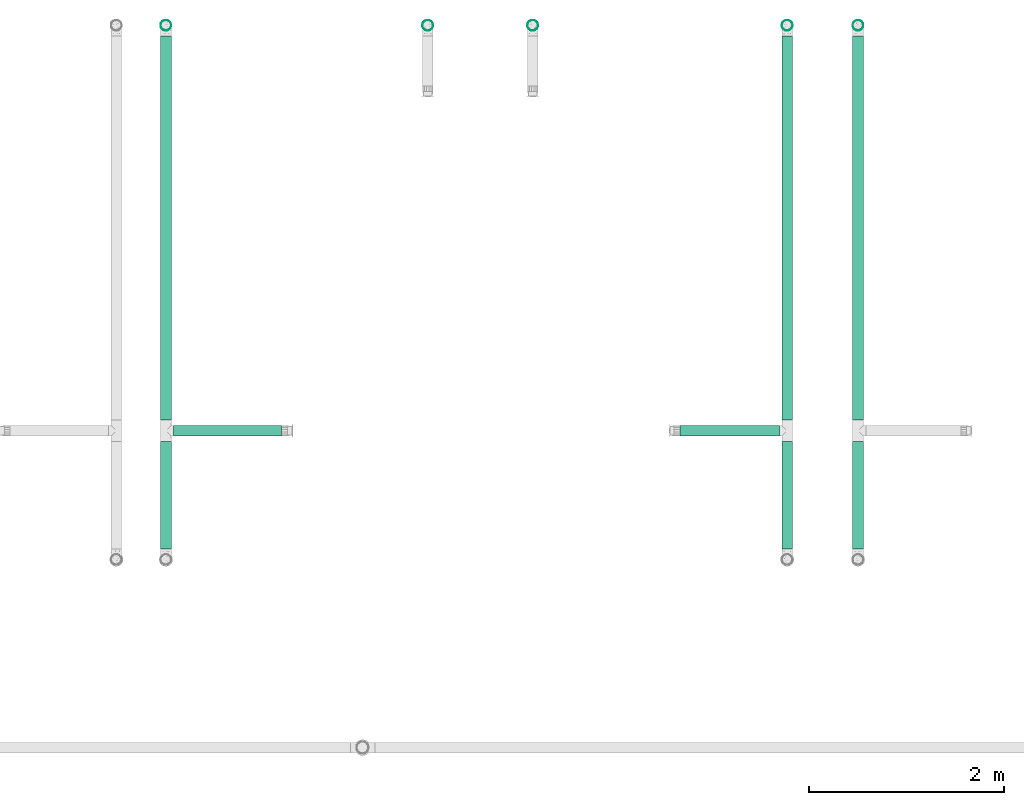
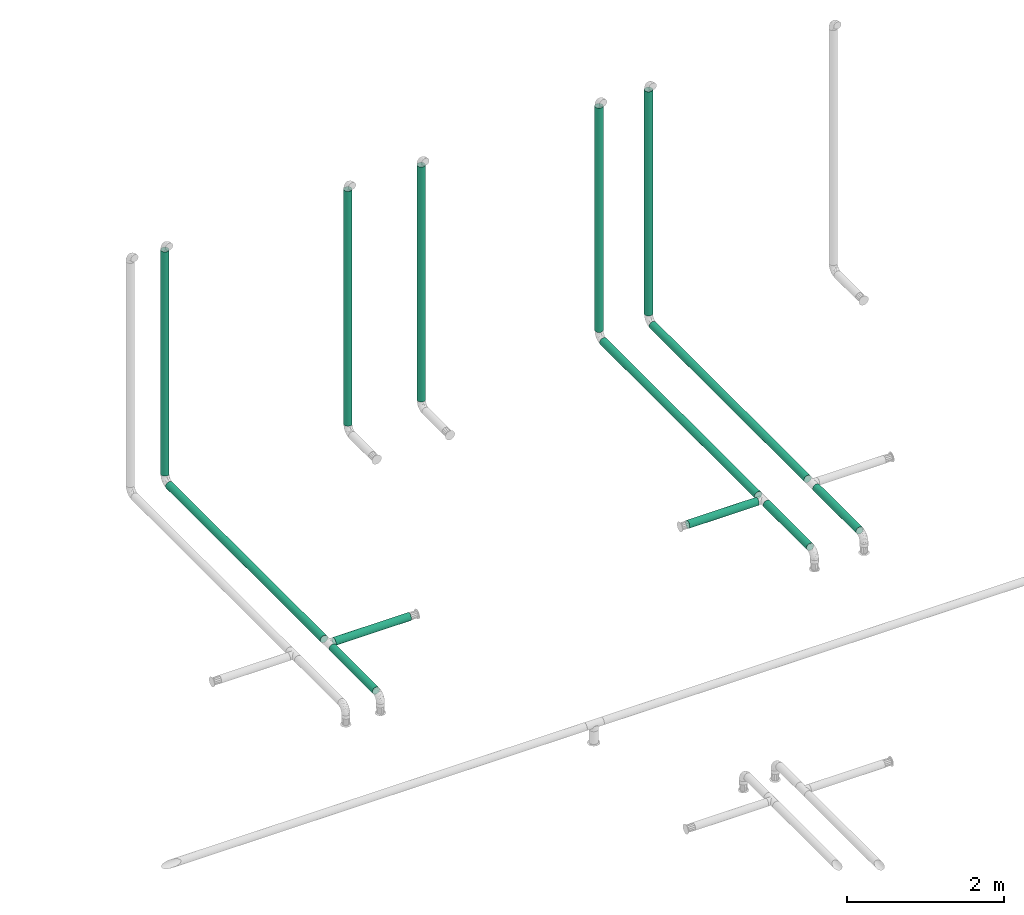
# One storey, part 10 of 115: 13 flow segments.
"""IFC2X3 building model written with IfcOpenShell, lengths in millimetres."""

from ifc_helpers import new_model, entity, si_unit, converted_unit, derived_unit, direction, frame, origin_with_axes, origin_2d_with_axis, place, context, subcontext, project, spatial, hollow_circle, extrude, source, transform, mapped, material, layer, layer_set, layer_usage, type_object, element, save


model = new_model("IFC2X3")

# Units and contexts
model_context = context("Model", 3, precision=1e-05, world=origin_with_axes(), true_north=direction((0.0, 1.0)))
body_context = subcontext(model_context, "Body", "Model", "MODEL_VIEW")
ifc_project = project(units=[si_unit("AREAUNIT", "SQUARE_METRE"), si_unit("VOLUMEUNIT", "CUBIC_METRE", prefix="DECI"), si_unit("TIMEUNIT", "SECOND"), si_unit("THERMODYNAMICTEMPERATUREUNIT", "DEGREE_CELSIUS"), si_unit("PRESSUREUNIT", "PASCAL"), si_unit("MASSUNIT", "GRAM", prefix="KILO"), si_unit("LENGTHUNIT", "METRE", prefix="MILLI"), si_unit("POWERUNIT", "WATT"), si_unit("ELECTRICCURRENTUNIT", "AMPERE"), si_unit("ELECTRICVOLTAGEUNIT", "VOLT"), derived_unit("VOLUMETRICFLOWRATEUNIT", [(si_unit("VOLUMEUNIT", "CUBIC_METRE", prefix="DECI"), 1), (si_unit("TIMEUNIT", "SECOND"), -1)]), derived_unit("LINEARVELOCITYUNIT", [(si_unit("LENGTHUNIT", "METRE"), 1), (si_unit("TIMEUNIT", "SECOND"), -1)]), derived_unit("MASSDENSITYUNIT", [(si_unit("MASSUNIT", "GRAM", prefix="KILO"), 1), (si_unit("VOLUMEUNIT", "CUBIC_METRE"), -1)]), converted_unit("PLANEANGLEUNIT", "DEGREE", entity("IfcRatioMeasure", 0.01745), si_unit("PLANEANGLEUNIT", "RADIAN"), dimensions=[0, 0, 0, 0, 0, 0, 0])], contexts=[model_context])

# Site, building, storey
site_placement = place(None, origin_with_axes())
site = spatial("IfcSite", under=ifc_project, at=site_placement, CompositionType="ELEMENT")
building_placement = place(site_placement, origin_with_axes())
building = spatial("IfcBuilding", under=site, at=building_placement, Name="mc-building", CompositionType="ELEMENT")
storey_placement = place(building_placement, frame((0.0, 0.0, 2950.0), z_axis=(0.0, 0.0, 1.0), x_axis=(1.0, 0.0, 0.0)))
storey = spatial("IfcBuildingStorey", under=building, at=storey_placement, Name="2. Korrus", CompositionType="ELEMENT", Elevation=2950.0)

# Flow segments
ifc_material = material(Name="FZ1")
ifc_layer = layer(ifc_material, 0.0)
ifc_layer_set = layer_set([ifc_layer], Name="FZ1")
ifc_layer_usage = layer_usage(ifc_layer_set, "AXIS1", "POSITIVE", 0.0)
duct_segment_type = type_object("IfcDuctSegmentType", PredefinedType="RIGIDSEGMENT")
shared_shape_1 = source(origin_with_axes(), body_context, "Body", "SweptSolid", [
    extrude(hollow_circle(Radius=55.0, WallThickness=2.0, at=origin_2d_with_axis()), frame((0.0, 0.0, 0.0), z_axis=(1.0, 0.0, 0.0), x_axis=(0.0, 1.0, 0.0)), (0.0, 0.0, 1.0), 3480.0),
])
for number, where, z_axis, x_axis in (
    (1, (33284.80157, 13663.57591, 2575.0), (1.0, 0.0, 0.0), (0.0, 0.0, 1.0)),
    (2, (34011.69824, 13663.57591, 2575.0), (1.0, 0.0, 0.0), (0.0, 0.0, 1.0)),
    (3, (26911.82755, 13663.57591, 2575.0), (1.0, 0.0, 0.0), (0.0, 0.0, 1.0)),
):
    element("IfcFlowSegment", number, at=place(storey_placement, frame(where, z_axis=z_axis, x_axis=x_axis)), inside=storey, type_object=duct_segment_type, material=ifc_layer_usage, context=body_context, shape_type="MappedRepresentation", body=[
        mapped(shared_shape_1, transform((0.0, 0.0, 0.0), scale=1.0)),
    ])
shared_shape_2 = source(origin_with_axes(), body_context, "Body", "SweptSolid", [
    extrude(hollow_circle(Radius=55.0, WallThickness=2.0, at=origin_2d_with_axis()), frame((0.0, 0.0, 0.0), z_axis=(1.0, 0.0, 0.0), x_axis=(0.0, 1.0, 0.0)), (0.0, 0.0, 1.0), 3645.0),
])
for number, where, z_axis, x_axis in (
    (4, (30674.56773, 13663.57591, 2410.0), (1.0, 0.0, 0.0), (0.0, 0.0, 1.0)),
    (5, (29597.94843, 13663.57591, 2410.0), (1.0, 0.0, 0.0), (0.0, 0.0, 1.0)),
):
    element("IfcFlowSegment", number, at=place(storey_placement, frame(where, z_axis=z_axis, x_axis=x_axis)), inside=storey, type_object=duct_segment_type, material=ifc_layer_usage, context=body_context, shape_type="MappedRepresentation", body=[
        mapped(shared_shape_2, transform((0.0, 0.0, 0.0), scale=1.0)),
    ])
shared_shape_3 = source(origin_with_axes(), body_context, "Body", "SweptSolid", [
    extrude(hollow_circle(Radius=55.0, WallThickness=2.0, at=origin_2d_with_axis()), frame((0.0, 0.0, 0.0), z_axis=(1.0, 0.0, 0.0), x_axis=(0.0, 1.0, 0.0)), (0.0, 0.0, 1.0), 1101.4),
])
for number, where, z_axis, x_axis in (
    (6, (33284.80157, 9395.0, 2465.0), (0.0, 0.0, 1.0), (0.0, -1.0, 0.0)),
    (7, (34011.69824, 9395.0, 2465.0), (0.0, 0.0, 1.0), (0.0, -1.0, 0.0)),
    (8, (26911.82755, 9395.0, 2465.0), (0.0, 0.0, 1.0), (0.0, -1.0, 0.0)),
):
    element("IfcFlowSegment", number, at=place(storey_placement, frame(where, z_axis=z_axis, x_axis=x_axis)), inside=storey, type_object=duct_segment_type, material=ifc_layer_usage, context=body_context, shape_type="MappedRepresentation", body=[
        mapped(shared_shape_3, transform((0.0, 0.0, 0.0), scale=1.0)),
    ])
shared_shape_4 = source(origin_with_axes(), body_context, "Body", "SweptSolid", [
    extrude(hollow_circle(Radius=55.0, WallThickness=2.0, at=origin_2d_with_axis()), frame((0.0, 0.0, 0.0), z_axis=(1.0, 0.0, 0.0), x_axis=(0.0, 1.0, 0.0)), (0.0, 0.0, 1.0), 3938.6),
])
for number, where, z_axis, x_axis in (
    (9, (33284.80157, 13553.57591, 2465.0), (0.0, 0.0, 1.0), (0.0, -1.0, 0.0)),
    (10, (34011.69824, 13553.57591, 2465.0), (0.0, 0.0, 1.0), (0.0, -1.0, 0.0)),
    (11, (26911.82755, 13553.57591, 2465.0), (0.0, 0.0, 1.0), (0.0, -1.0, 0.0)),
):
    element("IfcFlowSegment", number, at=place(storey_placement, frame(where, z_axis=z_axis, x_axis=x_axis)), inside=storey, type_object=duct_segment_type, material=ifc_layer_usage, context=body_context, shape_type="MappedRepresentation", body=[
        mapped(shared_shape_4, transform((0.0, 0.0, 0.0), scale=1.0)),
    ])
shared_shape_5 = source(origin_with_axes(), body_context, "Body", "SweptSolid", [
    extrude(hollow_circle(Radius=55.0, WallThickness=2.0, at=origin_2d_with_axis()), frame((0.0, 0.0, 0.0), z_axis=(1.0, 0.0, 0.0), x_axis=(0.0, 1.0, 0.0)), (0.0, 0.0, 1.0), 1020.0),
])
flow_segment_1_placement = place(storey_placement, frame((33204.80157, 9505.0, 2465.0), z_axis=(0.0, 0.0, 1.0), x_axis=(-1.0, 0.0, 0.0)))
element("IfcFlowSegment", 12, at=flow_segment_1_placement, inside=storey, type_object=duct_segment_type, material=ifc_layer_usage, context=body_context, shape_type="MappedRepresentation", body=[
    mapped(shared_shape_5, transform((0.0, 0.0, 0.0), scale=1.0)),
])
shared_shape_6 = source(origin_with_axes(), body_context, "Body", "SweptSolid", [
    extrude(hollow_circle(Radius=55.0, WallThickness=2.0, at=origin_2d_with_axis()), frame((0.0, 0.0, 0.0), z_axis=(1.0, 0.0, 0.0), x_axis=(0.0, 1.0, 0.0)), (0.0, 0.0, 1.0), 1107.9),
])
flow_segment_2_placement = place(storey_placement, frame((26991.82755, 9505.0, 2465.0), z_axis=(0.0, 0.0, 1.0), x_axis=(1.0, 0.0, 0.0)))
element("IfcFlowSegment", 13, at=flow_segment_2_placement, inside=storey, type_object=duct_segment_type, material=ifc_layer_usage, context=body_context, shape_type="MappedRepresentation", body=[
    mapped(shared_shape_6, transform((0.0, 0.0, 0.0), scale=1.0)),
])

save(model, "model.ifc")
